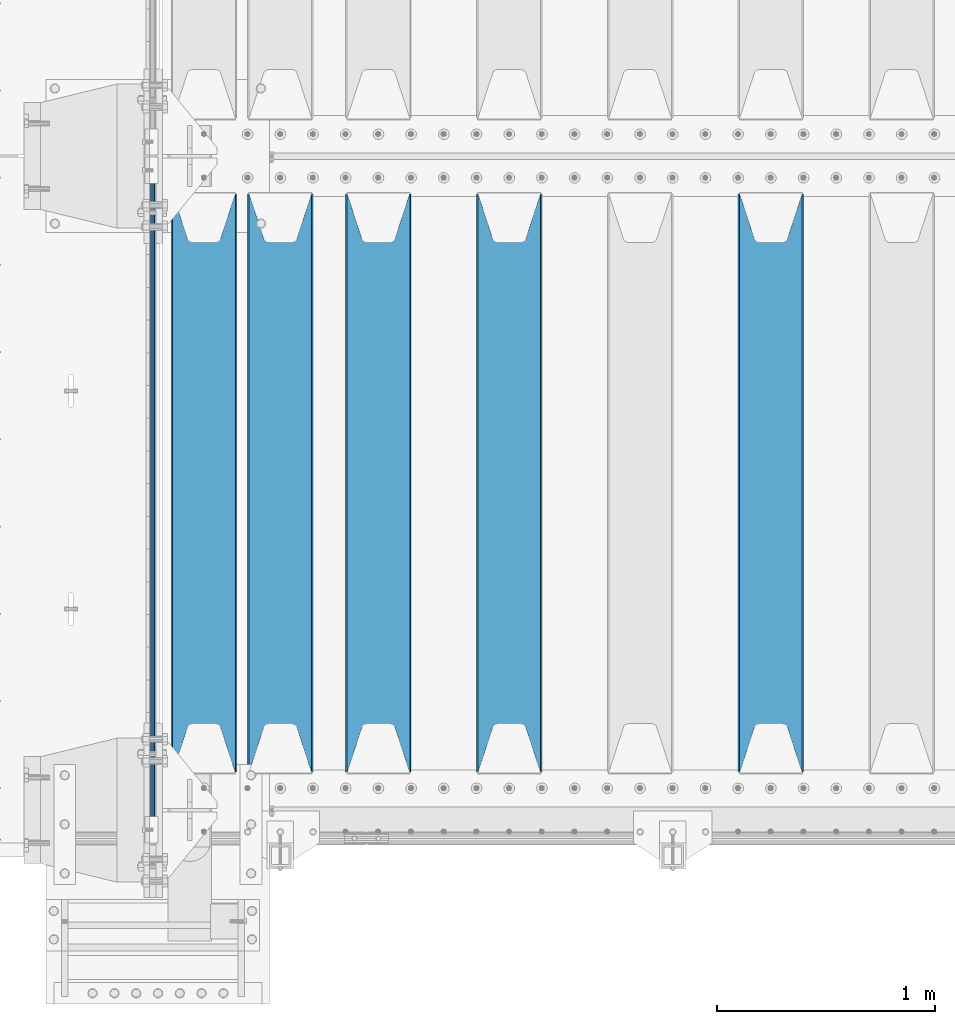
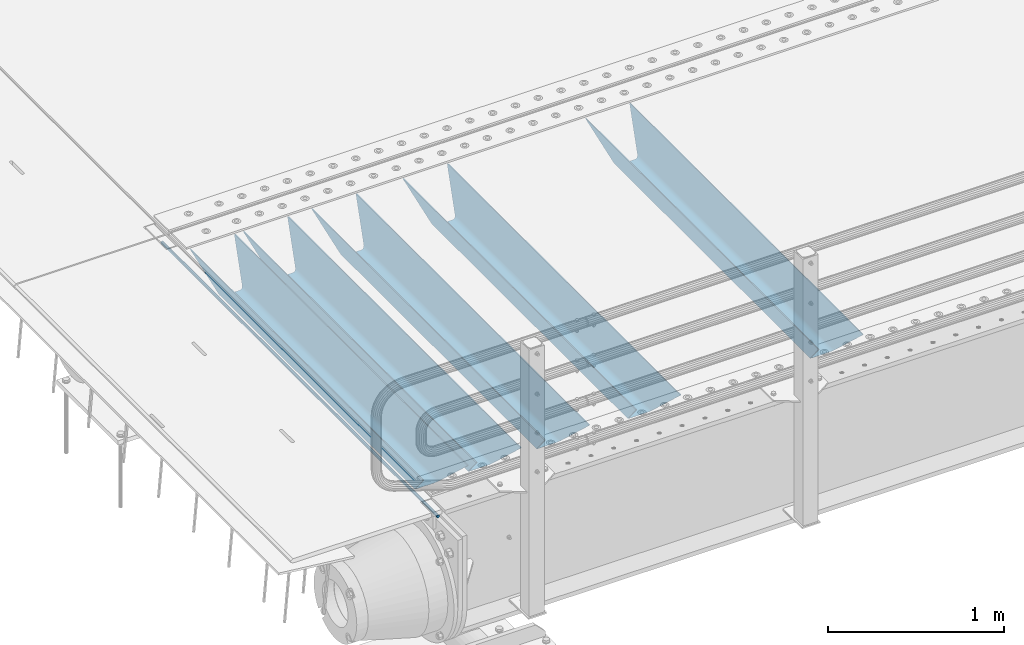
# One storey, part 107 of 247: 6 beams.
"""IFC2X3 building model written with IfcOpenShell, lengths in millimetres."""

from ifc_helpers import new_model, si_unit, frame, origin_with_axes, place, context, subcontext, project, spatial, faceted_brep, material, type_object, element, save


model = new_model("IFC2X3")

# Units and contexts
model_context = context("Model", 3, precision=1e-05, world=origin_with_axes())
body_context = subcontext(model_context, "Body", "Model", "MODEL_VIEW")
ifc_project = project(units=[si_unit("LENGTHUNIT", "METRE", prefix="MILLI"), si_unit("AREAUNIT", "SQUARE_METRE"), si_unit("VOLUMEUNIT", "CUBIC_METRE"), si_unit("MASSUNIT", "GRAM", prefix="KILO"), si_unit("TIMEUNIT", "SECOND"), si_unit("PLANEANGLEUNIT", "RADIAN"), si_unit("SOLIDANGLEUNIT", "STERADIAN"), si_unit("THERMODYNAMICTEMPERATUREUNIT", "DEGREE_CELSIUS"), si_unit("LUMINOUSINTENSITYUNIT", "LUMEN")], contexts=[model_context])

# Site, building, storey
site_placement = place(None, origin_with_axes())
site = spatial("IfcSite", under=ifc_project, at=site_placement, CompositionType="ELEMENT")
building_placement = place(site_placement, origin_with_axes())
building = spatial("IfcBuilding", under=site, at=building_placement, Name="Standard", CompositionType="ELEMENT")
storey_placement = place(building_placement, origin_with_axes())
storey = spatial("IfcBuildingStorey", under=building, at=storey_placement, Name="Undefined", CompositionType="ELEMENT", Elevation=0.0)

# Beams
ifc_material = material(Name="STEEL/S355N")
beam_type_1 = type_object("IfcBeamType", Name="D20", PredefinedType="NOTDEFINED")
beam_1_placement = place(storey_placement, frame((-35.0000000000327, -150.000000000022, -26.0000373887407), z_axis=(0.0, 0.0, 1.0), x_axis=(0.0, 1.0, 0.0)))
element("IfcBeam", 1, at=beam_1_placement, inside=storey, type_object=beam_type_1, material=ifc_material, ObjectType="D20", context=body_context, shape_type="Brep", body=[
    faceted_brep([(-5.6843418860808e-14, -9.99999999999989, 3.5527136788005e-15), (0.0, -7.07106781186531, -7.07106781186547), (3144.99999999998, -7.07106781186548, -7.07106781186548), (3144.99999999998, -10.0, 0.0), (-5.6843418860808e-14, 0.0, -10.0), (3144.99999999998, 0.0, -10.0), (0.0, 7.07106781186565, -7.07106781186547), (3144.99999999998, 7.07106781186548, -7.07106781186547), (-5.6843418860808e-14, 10.0000000000001, 3.5527136788005e-15), (3144.99999999998, 10.0, 0.0), (-5.6843418860808e-14, 7.07106781186553, 7.07106781186548), (3144.99999999998, 7.07106781186548, 7.07106781186548), (0.0, 0.0, 10.0), (3144.99999999998, 0.0, 10.0), (-5.6843418860808e-14, -7.07106781186542, 7.07106781186548), (3144.99999999998, -7.07106781186548, 7.07106781186548)], [[[0, 1, 2, 3]], [[1, 4, 5, 2]], [[4, 6, 7, 5]], [[6, 8, 9, 7]], [[8, 10, 11, 9]], [[10, 12, 13, 11]], [[12, 14, 15, 13]], [[14, 0, 3, 15]], [[5, 7, 9, 11, 13, 15, 3, 2]], [[14, 12, 10, 8, 6, 4, 1, 0]]]),
])
beam_type_2 = type_object("IfcBeamType", PredefinedType="NOTDEFINED")
beam_2_placement = place(storey_placement, frame((2800.0, 175.0, -115.0), z_axis=(0.0, 0.0, 1.0), x_axis=(0.0, 1.0, 0.0)))
element("IfcBeam", 2, at=beam_2_placement, inside=storey, type_object=beam_type_2, material=ifc_material, context=body_context, shape_type="Brep", body=[
    faceted_brep([(0.0, 150.0, 115.0), (0.0, 143.689999999999, 115.0), (2650.00000000297, 143.689999999999, 115.0), (2650.00000000297, 150.0, 115.0), (2650.00000000297, 142.059565218402, 110.0000000031), (2650.00000000297, 148.369565218403, 110.0000000031), (2441.90079219208, -80.1103600731112, -98.0992078077845), (2437.7588105432, -77.5672621345584, -102.241189456673), (2434.06523489746, -74.4080125315522, -105.934765102404), (2430.91086095089, -70.710272125576, -109.089139048974), (2428.37322971128, -66.5649389910068, -111.626770288588), (2426.51472138054, -62.0739139532889, -113.485278619323), (2425.38102192091, -57.3475956567672, -114.618978078955), (2424.99999999987, -52.5021667386536, -115.0), (2424.99999999987, 52.5021667386536, -115.0), (2425.38102192091, 57.3475956567672, -114.618978078955), (2426.51472138054, 62.0739139532889, -113.485278619323), (2428.37322971128, 66.5649389910068, -111.626770288588), (2430.91086095089, 70.710272125576, -109.089139048974), (2434.06523489746, 74.4080125315522, -105.934765102404), (2437.7588105432, 77.5672621345584, -102.241189456673), (2441.90079219208, 80.1103600731112, -98.0992078077846), (2446.38936140511, 81.9747917625791, -93.6106385947584), (2448.24948500409, 76.2713538057251, -91.7505149957729), (2444.62967112262, 74.76777986261, -95.3703288772456), (2441.28936334126, 72.7168944282894, -98.710636658607), (2438.31067330438, 70.1691124903846, -101.689326695487), (2435.76682334747, 67.1870637758839, -104.233176652398), (2433.72034654133, 63.8440531834895, -106.279653458539), (2432.22154950041, 60.222258798236, -107.778450499454), (2431.30727574265, 56.4107117849089, -108.692724257221), (2430.99999999987, 52.5031078186876, -109.0), (2430.99999999987, -52.5031078186876, -109.0), (2431.30727574265, -56.4107117849089, -108.692724257221), (2432.22154950041, -60.222258798236, -107.778450499454), (2433.72034654133, -63.8440531834895, -106.279653458539), (2435.76682334747, -67.1870637758839, -104.233176652398), (2438.31067330438, -70.1691124903846, -101.689326695487), (2441.28936334126, -72.7168944282894, -98.7106366586071), (2444.62967112262, -74.76777986261, -95.3703288772457), (2448.24948500409, -76.2713538057251, -91.7505149957729), (2650.00000000297, -142.059565218402, 110.0000000031), (2650.00000000297, -148.369565218403, 110.0000000031), (2446.38936140511, -81.9747917625791, -93.6106385947584), (2650.00000000297, -143.689999999999, 115.0), (2650.00000000297, -150.0, 115.0), (0.0, -143.689999999999, 115.0), (0.0, -150.0, 115.0), (0.0, -148.369565218261, 110.000000002663), (203.610638597422, -81.9747917625791, -93.6106385947584), (208.099207810448, -80.1103600731112, -98.0992078077845), (212.241189459336, -77.5672621345584, -102.241189456673), (215.934765105068, -74.4080125315522, -105.934765102404), (219.089139051637, -70.710272125576, -109.089139048974), (221.626770291251, -66.5649389910068, -111.626770288588), (223.485278621985, -62.0739139532889, -113.485278619323), (224.618978081617, -57.3475956567672, -114.618978078955), (225.000000002663, -52.5021667386536, -115.0), (225.000000002663, 52.5021667386536, -115.0), (224.618978081617, 57.3475956567672, -114.618978078955), (223.485278621985, 62.0739139532889, -113.485278619323), (221.626770291251, 66.5649389910068, -111.626770288588), (219.089139051637, 70.710272125576, -109.089139048974), (215.934765105068, 74.4080125315522, -105.934765102404), (212.241189459336, 77.5672621345584, -102.241189456673), (208.099207810448, 80.1103600731112, -98.0992078077846), (203.610638597422, 81.9747917625791, -93.6106385947584), (0.0, 148.369565218261, 110.000000002663), (0.0, 142.05956521826, 110.000000002663), (201.750514998436, 76.2713538057251, -91.7505149957729), (205.370328879908, 74.76777986261, -95.3703288772456), (208.710636661271, 72.7168944282894, -98.710636658607), (211.68932669815, 70.1691124903846, -101.689326695487), (214.233176655061, 67.1870637758839, -104.233176652398), (216.279653461202, 63.8440531834895, -106.279653458539), (217.778450502117, 60.222258798236, -107.778450499454), (218.692724259885, 56.4107117849089, -108.692724257221), (219.000000002663, 52.5031078186876, -109.0), (219.000000002663, -52.5031078186876, -109.0), (218.692724259885, -56.4107117849089, -108.692724257221), (217.778450502117, -60.222258798236, -107.778450499454), (216.279653461202, -63.8440531834895, -106.279653458539), (214.233176655061, -67.1870637758839, -104.233176652398), (211.68932669815, -70.1691124903846, -101.689326695487), (208.710636661271, -72.7168944282894, -98.7106366586071), (205.370328879908, -74.76777986261, -95.3703288772457), (201.750514998436, -76.2713538057251, -91.7505149957729), (0.0, -142.05956521826, 110.000000002663)], [[[0, 1, 2, 3]], [[3, 2, 4, 5]], [[6, 7, 8, 9, 10, 11, 12, 13, 14, 15, 16, 17, 18, 19, 20, 21, 22, 5, 4, 23, 24, 25, 26, 27, 28, 29, 30, 31, 32, 33, 34, 35, 36, 37, 38, 39, 40, 41, 42, 43]], [[44, 45, 42, 41]], [[46, 47, 45, 44]], [[43, 42, 45, 47, 48, 49]], [[6, 43, 49, 50]], [[7, 6, 50, 51]], [[8, 7, 51, 52]], [[9, 8, 52, 53]], [[10, 9, 53, 54]], [[11, 10, 54, 55]], [[12, 11, 55, 56]], [[13, 12, 56, 57]], [[14, 13, 57, 58]], [[15, 14, 58, 59]], [[16, 15, 59, 60]], [[17, 16, 60, 61]], [[18, 17, 61, 62]], [[19, 18, 62, 63]], [[20, 19, 63, 64]], [[21, 20, 64, 65]], [[22, 21, 65, 66]], [[0, 3, 5, 22, 66, 67]], [[1, 0, 67, 68]], [[23, 4, 2, 1, 68, 69]], [[24, 23, 69, 70]], [[25, 24, 70, 71]], [[26, 25, 71, 72]], [[27, 26, 72, 73]], [[28, 27, 73, 74]], [[29, 28, 74, 75]], [[30, 29, 75, 76]], [[31, 30, 76, 77]], [[32, 31, 77, 78]], [[33, 32, 78, 79]], [[34, 33, 79, 80]], [[35, 34, 80, 81]], [[36, 35, 81, 82]], [[37, 36, 82, 83]], [[38, 37, 83, 84]], [[39, 38, 84, 85]], [[40, 39, 85, 86]], [[46, 44, 41, 40, 86, 87]], [[47, 46, 87, 48]], [[86, 85, 84, 83, 82, 81, 80, 79, 78, 77, 76, 75, 74, 73, 72, 71, 70, 69, 68, 67, 66, 65, 64, 63, 62, 61, 60, 59, 58, 57, 56, 55, 54, 53, 52, 51, 50, 49, 48, 87]]]),
])
beam_3_placement = place(storey_placement, frame((1600.0, 175.0, -115.0), z_axis=(0.0, 0.0, 1.0), x_axis=(0.0, 1.0, 0.0)))
element("IfcBeam", 3, at=beam_3_placement, inside=storey, type_object=beam_type_2, material=ifc_material, context=body_context, shape_type="Brep", body=[
    faceted_brep([(0.0, 150.0, 115.0), (0.0, 143.689999999999, 115.0), (2650.00000000297, 143.689999999999, 115.0), (2650.00000000297, 150.0, 115.0), (2650.00000000297, 142.059565218402, 110.0000000031), (2650.00000000297, 148.369565218403, 110.0000000031), (2441.90079219208, -80.1103600731112, -98.0992078077845), (2437.7588105432, -77.5672621345584, -102.241189456673), (2434.06523489746, -74.4080125315522, -105.934765102404), (2430.91086095089, -70.710272125576, -109.089139048974), (2428.37322971128, -66.5649389910068, -111.626770288588), (2426.51472138054, -62.0739139532889, -113.485278619323), (2425.38102192091, -57.3475956567672, -114.618978078955), (2424.99999999987, -52.5021667386536, -115.0), (2424.99999999987, 52.5021667386536, -115.0), (2425.38102192091, 57.3475956567672, -114.618978078955), (2426.51472138054, 62.0739139532889, -113.485278619323), (2428.37322971128, 66.5649389910068, -111.626770288588), (2430.91086095089, 70.710272125576, -109.089139048974), (2434.06523489746, 74.4080125315522, -105.934765102404), (2437.7588105432, 77.5672621345584, -102.241189456673), (2441.90079219208, 80.1103600731112, -98.0992078077846), (2446.38936140511, 81.9747917625791, -93.6106385947584), (2448.24948500409, 76.2713538057251, -91.7505149957729), (2444.62967112262, 74.76777986261, -95.3703288772456), (2441.28936334126, 72.7168944282894, -98.710636658607), (2438.31067330438, 70.1691124903846, -101.689326695487), (2435.76682334747, 67.1870637758839, -104.233176652398), (2433.72034654133, 63.8440531834895, -106.279653458539), (2432.22154950041, 60.222258798236, -107.778450499454), (2431.30727574265, 56.4107117849089, -108.692724257221), (2430.99999999987, 52.5031078186876, -109.0), (2430.99999999987, -52.5031078186876, -109.0), (2431.30727574265, -56.4107117849089, -108.692724257221), (2432.22154950041, -60.222258798236, -107.778450499454), (2433.72034654133, -63.8440531834895, -106.279653458539), (2435.76682334747, -67.1870637758839, -104.233176652398), (2438.31067330438, -70.1691124903846, -101.689326695487), (2441.28936334126, -72.7168944282894, -98.7106366586071), (2444.62967112262, -74.76777986261, -95.3703288772457), (2448.24948500409, -76.2713538057251, -91.7505149957729), (2650.00000000297, -142.059565218402, 110.0000000031), (2650.00000000297, -148.369565218403, 110.0000000031), (2446.38936140511, -81.9747917625791, -93.6106385947584), (2650.00000000297, -143.689999999999, 115.0), (2650.00000000297, -150.0, 115.0), (0.0, -143.689999999999, 115.0), (0.0, -150.0, 115.0), (0.0, -148.369565218261, 110.000000002663), (203.610638597422, -81.9747917625791, -93.6106385947584), (208.099207810448, -80.1103600731112, -98.0992078077845), (212.241189459336, -77.5672621345584, -102.241189456673), (215.934765105068, -74.4080125315522, -105.934765102404), (219.089139051637, -70.710272125576, -109.089139048974), (221.626770291251, -66.5649389910068, -111.626770288588), (223.485278621985, -62.0739139532889, -113.485278619323), (224.618978081617, -57.3475956567672, -114.618978078955), (225.000000002663, -52.5021667386536, -115.0), (225.000000002663, 52.5021667386536, -115.0), (224.618978081617, 57.3475956567672, -114.618978078955), (223.485278621985, 62.0739139532889, -113.485278619323), (221.626770291251, 66.5649389910068, -111.626770288588), (219.089139051637, 70.710272125576, -109.089139048974), (215.934765105068, 74.4080125315522, -105.934765102404), (212.241189459336, 77.5672621345584, -102.241189456673), (208.099207810448, 80.1103600731112, -98.0992078077846), (203.610638597422, 81.9747917625791, -93.6106385947584), (0.0, 148.369565218261, 110.000000002663), (0.0, 142.05956521826, 110.000000002663), (201.750514998436, 76.2713538057251, -91.7505149957729), (205.370328879908, 74.76777986261, -95.3703288772456), (208.710636661271, 72.7168944282894, -98.710636658607), (211.68932669815, 70.1691124903846, -101.689326695487), (214.233176655061, 67.1870637758839, -104.233176652398), (216.279653461202, 63.8440531834895, -106.279653458539), (217.778450502117, 60.222258798236, -107.778450499454), (218.692724259885, 56.4107117849089, -108.692724257221), (219.000000002663, 52.5031078186876, -109.0), (219.000000002663, -52.5031078186876, -109.0), (218.692724259885, -56.4107117849089, -108.692724257221), (217.778450502117, -60.222258798236, -107.778450499454), (216.279653461202, -63.8440531834895, -106.279653458539), (214.233176655061, -67.1870637758839, -104.233176652398), (211.68932669815, -70.1691124903846, -101.689326695487), (208.710636661271, -72.7168944282894, -98.7106366586071), (205.370328879908, -74.76777986261, -95.3703288772457), (201.750514998436, -76.2713538057251, -91.7505149957729), (0.0, -142.05956521826, 110.000000002663)], [[[0, 1, 2, 3]], [[3, 2, 4, 5]], [[6, 7, 8, 9, 10, 11, 12, 13, 14, 15, 16, 17, 18, 19, 20, 21, 22, 5, 4, 23, 24, 25, 26, 27, 28, 29, 30, 31, 32, 33, 34, 35, 36, 37, 38, 39, 40, 41, 42, 43]], [[44, 45, 42, 41]], [[46, 47, 45, 44]], [[43, 42, 45, 47, 48, 49]], [[6, 43, 49, 50]], [[7, 6, 50, 51]], [[8, 7, 51, 52]], [[9, 8, 52, 53]], [[10, 9, 53, 54]], [[11, 10, 54, 55]], [[12, 11, 55, 56]], [[13, 12, 56, 57]], [[14, 13, 57, 58]], [[15, 14, 58, 59]], [[16, 15, 59, 60]], [[17, 16, 60, 61]], [[18, 17, 61, 62]], [[19, 18, 62, 63]], [[20, 19, 63, 64]], [[21, 20, 64, 65]], [[22, 21, 65, 66]], [[0, 3, 5, 22, 66, 67]], [[1, 0, 67, 68]], [[23, 4, 2, 1, 68, 69]], [[24, 23, 69, 70]], [[25, 24, 70, 71]], [[26, 25, 71, 72]], [[27, 26, 72, 73]], [[28, 27, 73, 74]], [[29, 28, 74, 75]], [[30, 29, 75, 76]], [[31, 30, 76, 77]], [[32, 31, 77, 78]], [[33, 32, 78, 79]], [[34, 33, 79, 80]], [[35, 34, 80, 81]], [[36, 35, 81, 82]], [[37, 36, 82, 83]], [[38, 37, 83, 84]], [[39, 38, 84, 85]], [[40, 39, 85, 86]], [[46, 44, 41, 40, 86, 87]], [[47, 46, 87, 48]], [[86, 85, 84, 83, 82, 81, 80, 79, 78, 77, 76, 75, 74, 73, 72, 71, 70, 69, 68, 67, 66, 65, 64, 63, 62, 61, 60, 59, 58, 57, 56, 55, 54, 53, 52, 51, 50, 49, 48, 87]]]),
])
beam_4_placement = place(storey_placement, frame((1000.0, 175.0, -115.0), z_axis=(0.0, 0.0, 1.0), x_axis=(0.0, 1.0, 0.0)))
element("IfcBeam", 4, at=beam_4_placement, inside=storey, type_object=beam_type_2, material=ifc_material, context=body_context, shape_type="Brep", body=[
    faceted_brep([(0.0, 150.0, 115.0), (0.0, 143.689999999999, 115.0), (2650.00000000297, 143.689999999999, 115.0), (2650.00000000297, 150.0, 115.0), (2650.00000000297, 142.059565218402, 110.0000000031), (2650.00000000297, 148.369565218403, 110.0000000031), (2441.90079219208, -80.1103600731112, -98.0992078077845), (2437.7588105432, -77.5672621345584, -102.241189456673), (2434.06523489746, -74.4080125315522, -105.934765102404), (2430.91086095089, -70.710272125576, -109.089139048974), (2428.37322971128, -66.5649389910068, -111.626770288588), (2426.51472138054, -62.0739139532889, -113.485278619323), (2425.38102192091, -57.3475956567672, -114.618978078955), (2424.99999999987, -52.5021667386536, -115.0), (2424.99999999987, 52.5021667386536, -115.0), (2425.38102192091, 57.3475956567672, -114.618978078955), (2426.51472138054, 62.0739139532889, -113.485278619323), (2428.37322971128, 66.5649389910068, -111.626770288588), (2430.91086095089, 70.710272125576, -109.089139048974), (2434.06523489746, 74.4080125315522, -105.934765102404), (2437.7588105432, 77.5672621345584, -102.241189456673), (2441.90079219208, 80.1103600731112, -98.0992078077846), (2446.38936140511, 81.9747917625791, -93.6106385947584), (2448.24948500409, 76.2713538057251, -91.7505149957729), (2444.62967112262, 74.76777986261, -95.3703288772456), (2441.28936334126, 72.7168944282894, -98.710636658607), (2438.31067330438, 70.1691124903846, -101.689326695487), (2435.76682334747, 67.1870637758839, -104.233176652398), (2433.72034654133, 63.8440531834895, -106.279653458539), (2432.22154950041, 60.222258798236, -107.778450499454), (2431.30727574265, 56.4107117849089, -108.692724257221), (2430.99999999987, 52.5031078186876, -109.0), (2430.99999999987, -52.5031078186876, -109.0), (2431.30727574265, -56.4107117849089, -108.692724257221), (2432.22154950041, -60.222258798236, -107.778450499454), (2433.72034654133, -63.8440531834895, -106.279653458539), (2435.76682334747, -67.1870637758839, -104.233176652398), (2438.31067330438, -70.1691124903846, -101.689326695487), (2441.28936334126, -72.7168944282894, -98.7106366586071), (2444.62967112262, -74.76777986261, -95.3703288772457), (2448.24948500409, -76.2713538057251, -91.7505149957729), (2650.00000000297, -142.059565218402, 110.0000000031), (2650.00000000297, -148.369565218403, 110.0000000031), (2446.38936140511, -81.9747917625791, -93.6106385947584), (2650.00000000297, -143.689999999999, 115.0), (2650.00000000297, -150.0, 115.0), (0.0, -143.689999999999, 115.0), (0.0, -150.0, 115.0), (0.0, -148.369565218261, 110.000000002663), (203.610638597422, -81.9747917625791, -93.6106385947584), (208.099207810448, -80.1103600731112, -98.0992078077845), (212.241189459336, -77.5672621345584, -102.241189456673), (215.934765105068, -74.4080125315522, -105.934765102404), (219.089139051637, -70.710272125576, -109.089139048974), (221.626770291251, -66.5649389910068, -111.626770288588), (223.485278621985, -62.0739139532889, -113.485278619323), (224.618978081617, -57.3475956567672, -114.618978078955), (225.000000002663, -52.5021667386536, -115.0), (225.000000002663, 52.5021667386536, -115.0), (224.618978081617, 57.3475956567672, -114.618978078955), (223.485278621985, 62.0739139532889, -113.485278619323), (221.626770291251, 66.5649389910068, -111.626770288588), (219.089139051637, 70.710272125576, -109.089139048974), (215.934765105068, 74.4080125315522, -105.934765102404), (212.241189459336, 77.5672621345584, -102.241189456673), (208.099207810448, 80.1103600731112, -98.0992078077846), (203.610638597422, 81.9747917625791, -93.6106385947584), (0.0, 148.369565218261, 110.000000002663), (0.0, 142.05956521826, 110.000000002663), (201.750514998436, 76.2713538057251, -91.7505149957729), (205.370328879908, 74.76777986261, -95.3703288772456), (208.710636661271, 72.7168944282894, -98.710636658607), (211.68932669815, 70.1691124903846, -101.689326695487), (214.233176655061, 67.1870637758839, -104.233176652398), (216.279653461202, 63.8440531834895, -106.279653458539), (217.778450502117, 60.222258798236, -107.778450499454), (218.692724259885, 56.4107117849089, -108.692724257221), (219.000000002663, 52.5031078186876, -109.0), (219.000000002663, -52.5031078186876, -109.0), (218.692724259885, -56.4107117849089, -108.692724257221), (217.778450502117, -60.222258798236, -107.778450499454), (216.279653461202, -63.8440531834895, -106.279653458539), (214.233176655061, -67.1870637758839, -104.233176652398), (211.68932669815, -70.1691124903846, -101.689326695487), (208.710636661271, -72.7168944282894, -98.7106366586071), (205.370328879908, -74.76777986261, -95.3703288772457), (201.750514998436, -76.2713538057251, -91.7505149957729), (0.0, -142.05956521826, 110.000000002663)], [[[0, 1, 2, 3]], [[3, 2, 4, 5]], [[6, 7, 8, 9, 10, 11, 12, 13, 14, 15, 16, 17, 18, 19, 20, 21, 22, 5, 4, 23, 24, 25, 26, 27, 28, 29, 30, 31, 32, 33, 34, 35, 36, 37, 38, 39, 40, 41, 42, 43]], [[44, 45, 42, 41]], [[46, 47, 45, 44]], [[43, 42, 45, 47, 48, 49]], [[6, 43, 49, 50]], [[7, 6, 50, 51]], [[8, 7, 51, 52]], [[9, 8, 52, 53]], [[10, 9, 53, 54]], [[11, 10, 54, 55]], [[12, 11, 55, 56]], [[13, 12, 56, 57]], [[14, 13, 57, 58]], [[15, 14, 58, 59]], [[16, 15, 59, 60]], [[17, 16, 60, 61]], [[18, 17, 61, 62]], [[19, 18, 62, 63]], [[20, 19, 63, 64]], [[21, 20, 64, 65]], [[22, 21, 65, 66]], [[0, 3, 5, 22, 66, 67]], [[1, 0, 67, 68]], [[23, 4, 2, 1, 68, 69]], [[24, 23, 69, 70]], [[25, 24, 70, 71]], [[26, 25, 71, 72]], [[27, 26, 72, 73]], [[28, 27, 73, 74]], [[29, 28, 74, 75]], [[30, 29, 75, 76]], [[31, 30, 76, 77]], [[32, 31, 77, 78]], [[33, 32, 78, 79]], [[34, 33, 79, 80]], [[35, 34, 80, 81]], [[36, 35, 81, 82]], [[37, 36, 82, 83]], [[38, 37, 83, 84]], [[39, 38, 84, 85]], [[40, 39, 85, 86]], [[46, 44, 41, 40, 86, 87]], [[47, 46, 87, 48]], [[86, 85, 84, 83, 82, 81, 80, 79, 78, 77, 76, 75, 74, 73, 72, 71, 70, 69, 68, 67, 66, 65, 64, 63, 62, 61, 60, 59, 58, 57, 56, 55, 54, 53, 52, 51, 50, 49, 48, 87]]]),
])
beam_5_placement = place(storey_placement, frame((550.0, 175.0, -115.0), z_axis=(0.0, 0.0, 1.0), x_axis=(0.0, 1.0, 0.0)))
element("IfcBeam", 5, at=beam_5_placement, inside=storey, type_object=beam_type_2, material=ifc_material, context=body_context, shape_type="Brep", body=[
    faceted_brep([(0.0, 150.0, 115.0), (0.0, 143.689999999999, 115.0), (2650.00000000297, 143.689999999999, 115.0), (2650.00000000297, 150.0, 115.0), (2650.00000000297, 142.059565218402, 110.0000000031), (2650.00000000297, 148.369565218403, 110.0000000031), (2441.90079219208, -80.1103600731112, -98.0992078077845), (2437.7588105432, -77.5672621345584, -102.241189456673), (2434.06523489746, -74.4080125315522, -105.934765102404), (2430.91086095089, -70.710272125576, -109.089139048974), (2428.37322971128, -66.5649389910068, -111.626770288588), (2426.51472138054, -62.0739139532889, -113.485278619323), (2425.38102192091, -57.3475956567672, -114.618978078955), (2424.99999999987, -52.5021667386536, -115.0), (2424.99999999987, 52.5021667386536, -115.0), (2425.38102192091, 57.3475956567672, -114.618978078955), (2426.51472138054, 62.0739139532889, -113.485278619323), (2428.37322971128, 66.5649389910068, -111.626770288588), (2430.91086095089, 70.710272125576, -109.089139048974), (2434.06523489746, 74.4080125315522, -105.934765102404), (2437.7588105432, 77.5672621345584, -102.241189456673), (2441.90079219208, 80.1103600731112, -98.0992078077846), (2446.38936140511, 81.9747917625791, -93.6106385947584), (2448.24948500409, 76.2713538057251, -91.7505149957729), (2444.62967112262, 74.76777986261, -95.3703288772456), (2441.28936334126, 72.7168944282894, -98.710636658607), (2438.31067330438, 70.1691124903846, -101.689326695487), (2435.76682334747, 67.1870637758839, -104.233176652398), (2433.72034654133, 63.8440531834895, -106.279653458539), (2432.22154950041, 60.222258798236, -107.778450499454), (2431.30727574265, 56.4107117849089, -108.692724257221), (2430.99999999987, 52.5031078186876, -109.0), (2430.99999999987, -52.5031078186876, -109.0), (2431.30727574265, -56.4107117849089, -108.692724257221), (2432.22154950041, -60.222258798236, -107.778450499454), (2433.72034654133, -63.8440531834895, -106.279653458539), (2435.76682334747, -67.1870637758839, -104.233176652398), (2438.31067330438, -70.1691124903846, -101.689326695487), (2441.28936334126, -72.7168944282894, -98.7106366586071), (2444.62967112262, -74.76777986261, -95.3703288772457), (2448.24948500409, -76.2713538057251, -91.7505149957729), (2650.00000000297, -142.059565218402, 110.0000000031), (2650.00000000297, -148.369565218403, 110.0000000031), (2446.38936140511, -81.9747917625791, -93.6106385947584), (2650.00000000297, -143.689999999999, 115.0), (2650.00000000297, -150.0, 115.0), (0.0, -143.689999999999, 115.0), (0.0, -150.0, 115.0), (0.0, -148.369565218261, 110.000000002663), (203.610638597422, -81.9747917625791, -93.6106385947584), (208.099207810448, -80.1103600731112, -98.0992078077845), (212.241189459336, -77.5672621345584, -102.241189456673), (215.934765105068, -74.4080125315522, -105.934765102404), (219.089139051637, -70.710272125576, -109.089139048974), (221.626770291251, -66.5649389910068, -111.626770288588), (223.485278621985, -62.0739139532889, -113.485278619323), (224.618978081617, -57.3475956567672, -114.618978078955), (225.000000002663, -52.5021667386536, -115.0), (225.000000002663, 52.5021667386536, -115.0), (224.618978081617, 57.3475956567672, -114.618978078955), (223.485278621985, 62.0739139532889, -113.485278619323), (221.626770291251, 66.5649389910068, -111.626770288588), (219.089139051637, 70.710272125576, -109.089139048974), (215.934765105068, 74.4080125315522, -105.934765102404), (212.241189459336, 77.5672621345584, -102.241189456673), (208.099207810448, 80.1103600731112, -98.0992078077846), (203.610638597422, 81.9747917625791, -93.6106385947584), (0.0, 148.369565218261, 110.000000002663), (0.0, 142.05956521826, 110.000000002663), (201.750514998436, 76.2713538057251, -91.7505149957729), (205.370328879908, 74.76777986261, -95.3703288772456), (208.710636661271, 72.7168944282894, -98.710636658607), (211.68932669815, 70.1691124903846, -101.689326695487), (214.233176655061, 67.1870637758839, -104.233176652398), (216.279653461202, 63.8440531834895, -106.279653458539), (217.778450502117, 60.222258798236, -107.778450499454), (218.692724259885, 56.4107117849089, -108.692724257221), (219.000000002663, 52.5031078186876, -109.0), (219.000000002663, -52.5031078186876, -109.0), (218.692724259885, -56.4107117849089, -108.692724257221), (217.778450502117, -60.222258798236, -107.778450499454), (216.279653461202, -63.8440531834895, -106.279653458539), (214.233176655061, -67.1870637758839, -104.233176652398), (211.68932669815, -70.1691124903846, -101.689326695487), (208.710636661271, -72.7168944282894, -98.7106366586071), (205.370328879908, -74.76777986261, -95.3703288772457), (201.750514998436, -76.2713538057251, -91.7505149957729), (0.0, -142.05956521826, 110.000000002663)], [[[0, 1, 2, 3]], [[3, 2, 4, 5]], [[6, 7, 8, 9, 10, 11, 12, 13, 14, 15, 16, 17, 18, 19, 20, 21, 22, 5, 4, 23, 24, 25, 26, 27, 28, 29, 30, 31, 32, 33, 34, 35, 36, 37, 38, 39, 40, 41, 42, 43]], [[44, 45, 42, 41]], [[46, 47, 45, 44]], [[43, 42, 45, 47, 48, 49]], [[6, 43, 49, 50]], [[7, 6, 50, 51]], [[8, 7, 51, 52]], [[9, 8, 52, 53]], [[10, 9, 53, 54]], [[11, 10, 54, 55]], [[12, 11, 55, 56]], [[13, 12, 56, 57]], [[14, 13, 57, 58]], [[15, 14, 58, 59]], [[16, 15, 59, 60]], [[17, 16, 60, 61]], [[18, 17, 61, 62]], [[19, 18, 62, 63]], [[20, 19, 63, 64]], [[21, 20, 64, 65]], [[22, 21, 65, 66]], [[0, 3, 5, 22, 66, 67]], [[1, 0, 67, 68]], [[23, 4, 2, 1, 68, 69]], [[24, 23, 69, 70]], [[25, 24, 70, 71]], [[26, 25, 71, 72]], [[27, 26, 72, 73]], [[28, 27, 73, 74]], [[29, 28, 74, 75]], [[30, 29, 75, 76]], [[31, 30, 76, 77]], [[32, 31, 77, 78]], [[33, 32, 78, 79]], [[34, 33, 79, 80]], [[35, 34, 80, 81]], [[36, 35, 81, 82]], [[37, 36, 82, 83]], [[38, 37, 83, 84]], [[39, 38, 84, 85]], [[40, 39, 85, 86]], [[46, 44, 41, 40, 86, 87]], [[47, 46, 87, 48]], [[86, 85, 84, 83, 82, 81, 80, 79, 78, 77, 76, 75, 74, 73, 72, 71, 70, 69, 68, 67, 66, 65, 64, 63, 62, 61, 60, 59, 58, 57, 56, 55, 54, 53, 52, 51, 50, 49, 48, 87]]]),
])
beam_6_placement = place(storey_placement, frame((200.0, 175.0, -115.0), z_axis=(0.0, 0.0, 1.0), x_axis=(0.0, 1.0, 0.0)))
element("IfcBeam", 6, at=beam_6_placement, inside=storey, type_object=beam_type_2, material=ifc_material, context=body_context, shape_type="Brep", body=[
    faceted_brep([(0.0, 150.0, 115.0), (0.0, 143.689999999999, 115.0), (2650.00000000297, 143.689999999999, 115.0), (2650.00000000297, 150.0, 115.0), (2650.00000000297, 142.059565218402, 110.0000000031), (2650.00000000297, 148.369565218403, 110.0000000031), (2441.90079219208, -80.1103600731112, -98.0992078077845), (2437.7588105432, -77.5672621345584, -102.241189456673), (2434.06523489746, -74.4080125315522, -105.934765102404), (2430.91086095089, -70.710272125576, -109.089139048974), (2428.37322971128, -66.5649389910068, -111.626770288588), (2426.51472138054, -62.0739139532889, -113.485278619323), (2425.38102192091, -57.3475956567672, -114.618978078955), (2424.99999999987, -52.5021667386536, -115.0), (2424.99999999987, 52.5021667386536, -115.0), (2425.38102192091, 57.3475956567672, -114.618978078955), (2426.51472138054, 62.0739139532889, -113.485278619323), (2428.37322971128, 66.5649389910068, -111.626770288588), (2430.91086095089, 70.710272125576, -109.089139048974), (2434.06523489746, 74.4080125315522, -105.934765102404), (2437.7588105432, 77.5672621345584, -102.241189456673), (2441.90079219208, 80.1103600731112, -98.0992078077846), (2446.38936140511, 81.9747917625791, -93.6106385947584), (2448.24948500409, 76.2713538057251, -91.7505149957729), (2444.62967112262, 74.76777986261, -95.3703288772456), (2441.28936334126, 72.7168944282894, -98.710636658607), (2438.31067330438, 70.1691124903846, -101.689326695487), (2435.76682334747, 67.1870637758839, -104.233176652398), (2433.72034654133, 63.8440531834895, -106.279653458539), (2432.22154950041, 60.222258798236, -107.778450499454), (2431.30727574265, 56.4107117849089, -108.692724257221), (2430.99999999987, 52.5031078186876, -109.0), (2430.99999999987, -52.5031078186876, -109.0), (2431.30727574265, -56.4107117849089, -108.692724257221), (2432.22154950041, -60.222258798236, -107.778450499454), (2433.72034654133, -63.8440531834895, -106.279653458539), (2435.76682334747, -67.1870637758839, -104.233176652398), (2438.31067330438, -70.1691124903846, -101.689326695487), (2441.28936334126, -72.7168944282894, -98.7106366586071), (2444.62967112262, -74.76777986261, -95.3703288772457), (2448.24948500409, -76.2713538057251, -91.7505149957729), (2650.00000000297, -142.059565218402, 110.0000000031), (2650.00000000297, -148.369565218403, 110.0000000031), (2446.38936140511, -81.9747917625791, -93.6106385947584), (2650.00000000297, -143.689999999999, 115.0), (2650.00000000297, -150.0, 115.0), (0.0, -143.689999999999, 115.0), (0.0, -150.0, 115.0), (0.0, -148.369565218261, 110.000000002663), (203.610638597422, -81.9747917625791, -93.6106385947584), (208.099207810448, -80.1103600731112, -98.0992078077845), (212.241189459336, -77.5672621345584, -102.241189456673), (215.934765105068, -74.4080125315522, -105.934765102404), (219.089139051637, -70.710272125576, -109.089139048974), (221.626770291251, -66.5649389910068, -111.626770288588), (223.485278621985, -62.0739139532889, -113.485278619323), (224.618978081617, -57.3475956567672, -114.618978078955), (225.000000002663, -52.5021667386536, -115.0), (225.000000002663, 52.5021667386536, -115.0), (224.618978081617, 57.3475956567672, -114.618978078955), (223.485278621985, 62.0739139532889, -113.485278619323), (221.626770291251, 66.5649389910068, -111.626770288588), (219.089139051637, 70.710272125576, -109.089139048974), (215.934765105068, 74.4080125315522, -105.934765102404), (212.241189459336, 77.5672621345584, -102.241189456673), (208.099207810448, 80.1103600731112, -98.0992078077846), (203.610638597422, 81.9747917625791, -93.6106385947584), (0.0, 148.369565218261, 110.000000002663), (0.0, 142.05956521826, 110.000000002663), (201.750514998436, 76.2713538057251, -91.7505149957729), (205.370328879908, 74.76777986261, -95.3703288772456), (208.710636661271, 72.7168944282894, -98.710636658607), (211.68932669815, 70.1691124903846, -101.689326695487), (214.233176655061, 67.1870637758839, -104.233176652398), (216.279653461202, 63.8440531834895, -106.279653458539), (217.778450502117, 60.222258798236, -107.778450499454), (218.692724259885, 56.4107117849089, -108.692724257221), (219.000000002663, 52.5031078186876, -109.0), (219.000000002663, -52.5031078186876, -109.0), (218.692724259885, -56.4107117849089, -108.692724257221), (217.778450502117, -60.222258798236, -107.778450499454), (216.279653461202, -63.8440531834895, -106.279653458539), (214.233176655061, -67.1870637758839, -104.233176652398), (211.68932669815, -70.1691124903846, -101.689326695487), (208.710636661271, -72.7168944282894, -98.7106366586071), (205.370328879908, -74.76777986261, -95.3703288772457), (201.750514998436, -76.2713538057251, -91.7505149957729), (0.0, -142.05956521826, 110.000000002663)], [[[0, 1, 2, 3]], [[3, 2, 4, 5]], [[6, 7, 8, 9, 10, 11, 12, 13, 14, 15, 16, 17, 18, 19, 20, 21, 22, 5, 4, 23, 24, 25, 26, 27, 28, 29, 30, 31, 32, 33, 34, 35, 36, 37, 38, 39, 40, 41, 42, 43]], [[44, 45, 42, 41]], [[46, 47, 45, 44]], [[43, 42, 45, 47, 48, 49]], [[6, 43, 49, 50]], [[7, 6, 50, 51]], [[8, 7, 51, 52]], [[9, 8, 52, 53]], [[10, 9, 53, 54]], [[11, 10, 54, 55]], [[12, 11, 55, 56]], [[13, 12, 56, 57]], [[14, 13, 57, 58]], [[15, 14, 58, 59]], [[16, 15, 59, 60]], [[17, 16, 60, 61]], [[18, 17, 61, 62]], [[19, 18, 62, 63]], [[20, 19, 63, 64]], [[21, 20, 64, 65]], [[22, 21, 65, 66]], [[0, 3, 5, 22, 66, 67]], [[1, 0, 67, 68]], [[23, 4, 2, 1, 68, 69]], [[24, 23, 69, 70]], [[25, 24, 70, 71]], [[26, 25, 71, 72]], [[27, 26, 72, 73]], [[28, 27, 73, 74]], [[29, 28, 74, 75]], [[30, 29, 75, 76]], [[31, 30, 76, 77]], [[32, 31, 77, 78]], [[33, 32, 78, 79]], [[34, 33, 79, 80]], [[35, 34, 80, 81]], [[36, 35, 81, 82]], [[37, 36, 82, 83]], [[38, 37, 83, 84]], [[39, 38, 84, 85]], [[40, 39, 85, 86]], [[46, 44, 41, 40, 86, 87]], [[47, 46, 87, 48]], [[86, 85, 84, 83, 82, 81, 80, 79, 78, 77, 76, 75, 74, 73, 72, 71, 70, 69, 68, 67, 66, 65, 64, 63, 62, 61, 60, 59, 58, 57, 56, 55, 54, 53, 52, 51, 50, 49, 48, 87]]]),
])

save(model, "model.ifc")
